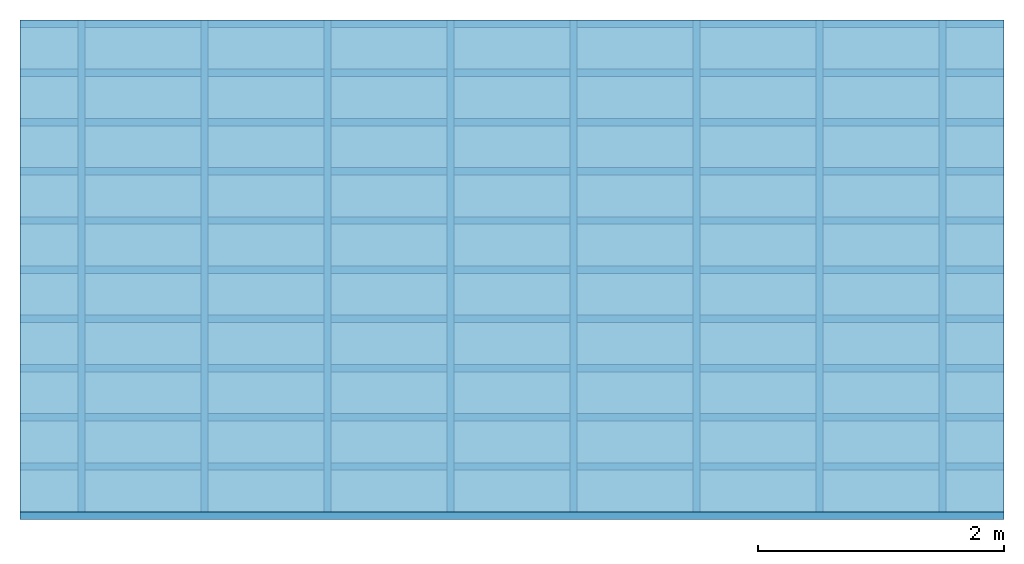
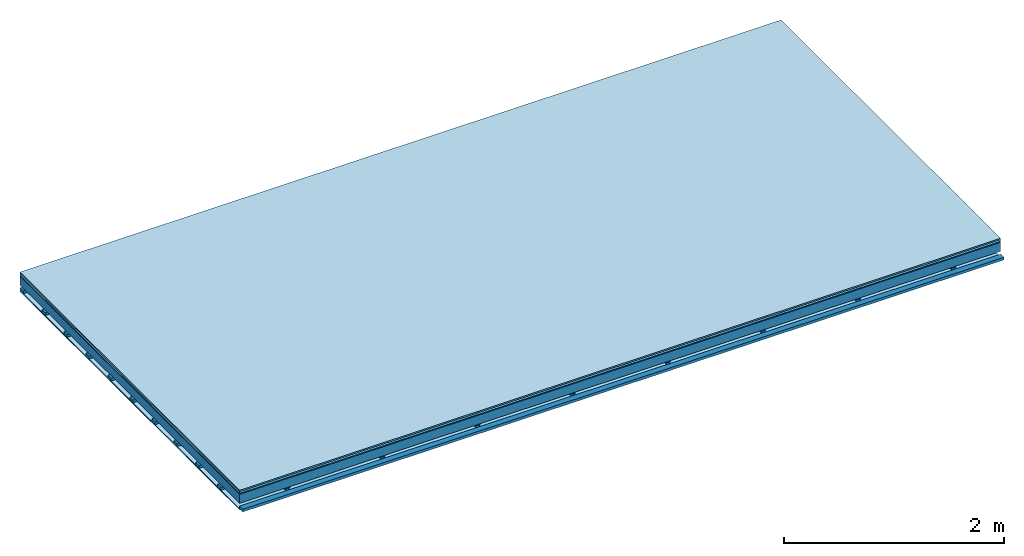
# One storey: 5 plates, 3 members, 1 element without a shape of its own.
"""IFC4 building model written with IfcOpenShell, lengths in metres."""

from ifc_helpers import new_model, si_unit, derived_unit, direction, frame, frame_2d, origin, origin_with_axes, place, context, project, spatial, polyline, rectangle, outline, extrude, material, layer, layer_set, type_object, element, aggregate, save


model = new_model("IFC4")

# Units and contexts
plan_context = context("Plan", 3, precision=1e-05, world=origin(), true_north=direction((0.0, 1.0)))
model_context = context("Model", 3, precision=1e-05, world=origin(), true_north=direction((0.0, 1.0)))
ifc_project = project(units=[si_unit("LENGTHUNIT", "METRE"), derived_unit("SOUNDPRESSUREUNIT", [(si_unit("PRESSUREUNIT", "PASCAL", prefix="MICRO"), 0)]), si_unit("ENERGYUNIT", "JOULE", prefix="MEGA"), si_unit("MASSUNIT", "GRAM", prefix="KILO"), derived_unit("THERMALTRANSMITTANCEUNIT", [(si_unit("POWERUNIT", "WATT"), 1), (si_unit("AREAUNIT", "SQUARE_METRE"), -1), (si_unit("THERMODYNAMICTEMPERATUREUNIT", "KELVIN"), -1)]), derived_unit("AREADENSITYUNIT", [(si_unit("MASSUNIT", "GRAM", prefix="KILO"), 1), (si_unit("AREAUNIT", "SQUARE_METRE"), -1)]), derived_unit("USERDEFINED", [(si_unit("ENERGYUNIT", "JOULE", prefix="MEGA"), 1), (si_unit("AREAUNIT", "SQUARE_METRE"), -1)])], contexts=[plan_context, model_context])

# Site, building, storey
site = spatial("IfcSite", under=ifc_project)
building_placement = place(None, origin())
building = spatial("IfcBuilding", under=site, at=building_placement)
storey_placement = place(building_placement, origin())
storey = spatial("IfcBuildingStorey", under=building, at=storey_placement)

# Slab, members, plates
ifc_material_1 = material(Category="11.013")
ifc_layer_1 = layer(ifc_material_1, 0.015, Name="Flooring")
ifc_material_2 = material(Category="03.007")
ifc_layer_2 = layer(ifc_material_2, 0.02, Name="On-material")
ifc_material_3 = material(Name="Wood fiber generic product", Category="10.009")
ifc_layer_3 = layer(ifc_material_3, 0.01, Name="Impact sound insulation")
ifc_material_4 = material(Name="no composite action")
ifc_layer_4 = layer(ifc_material_4, 0.0, Name="Bond")
ifc_layer_5 = layer(None, 0.1, Name="Supporting structure")
ifc_layer_6 = layer(ifc_material_4, 0.0, Name="Bond")
ifc_layer_7 = layer(None, 0.03, Name="Coupling")
ifc_layer_8 = layer(None, 0.03, Name="Battens / profiles")
ifc_material_5 = material(Name="Plasterboard type A", Category="03.008")
ifc_layer_9 = layer(ifc_material_5, 0.0125, Name="Ceiling covering 1st layer")
ifc_material_6 = material(Category="04.001")
ifc_layer_10 = layer(ifc_material_6, 0.003, Name="Surface / treatment")
ifc_layer_set = layer_set([ifc_layer_1, ifc_layer_2, ifc_layer_3, ifc_layer_4, ifc_layer_5, ifc_layer_6, ifc_layer_7, ifc_layer_8, ifc_layer_9, ifc_layer_10])
slab_type = type_object("IfcSlabType", Name="A2095", PredefinedType="NOTDEFINED", material=ifc_layer_set)
slab_placement = place(None, frame((0.0, 0.0, 0.0), z_axis=(0.0, 0.0, -1.0), x_axis=(1.0, 0.0, 0.0)))
slab = element("IfcSlab", 1, at=slab_placement, inside=storey, type_object=slab_type, material=ifc_layer_set, Name="Slab #1")
ifc_material_7 = material(Name="Solid timber panel")
member_1_placement = place(slab_placement, origin())
member_1 = element("IfcMember", 2, at=member_1_placement, material=ifc_material_7, Name="Supporting structure", context=plan_context, shape_type="SweptSolid", body=[
    extrude(rectangle(XDim=1.0, YDim=0.1, at=frame_2d((0.5, 0.05), x_axis=(1.0, 0.0))), frame((0.0, 4.0, 0.045), z_axis=(0.0, -1.0, 0.0), x_axis=(1.0, 0.0, 0.0)), (0.0, 0.0, 1.0), 4.0),
    extrude(rectangle(XDim=1.0, YDim=0.1, at=frame_2d((0.5, 0.05), x_axis=(1.0, 0.0))), frame((1.0, 4.0, 0.045), z_axis=(0.0, -1.0, 0.0), x_axis=(1.0, 0.0, 0.0)), (0.0, 0.0, 1.0), 4.0),
    extrude(rectangle(XDim=1.0, YDim=0.1, at=frame_2d((0.5, 0.05), x_axis=(1.0, 0.0))), frame((2.0, 4.0, 0.045), z_axis=(0.0, -1.0, 0.0), x_axis=(1.0, 0.0, 0.0)), (0.0, 0.0, 1.0), 4.0),
    extrude(rectangle(XDim=1.0, YDim=0.1, at=frame_2d((0.5, 0.05), x_axis=(1.0, 0.0))), frame((3.0, 4.0, 0.045), z_axis=(0.0, -1.0, 0.0), x_axis=(1.0, 0.0, 0.0)), (0.0, 0.0, 1.0), 4.0),
    extrude(rectangle(XDim=1.0, YDim=0.1, at=frame_2d((0.5, 0.05), x_axis=(1.0, 0.0))), frame((4.0, 4.0, 0.045), z_axis=(0.0, -1.0, 0.0), x_axis=(1.0, 0.0, 0.0)), (0.0, 0.0, 1.0), 4.0),
    extrude(rectangle(XDim=1.0, YDim=0.1, at=frame_2d((0.5, 0.05), x_axis=(1.0, 0.0))), frame((5.0, 4.0, 0.045), z_axis=(0.0, -1.0, 0.0), x_axis=(1.0, 0.0, 0.0)), (0.0, 0.0, 1.0), 4.0),
    extrude(rectangle(XDim=1.0, YDim=0.1, at=frame_2d((0.5, 0.05), x_axis=(1.0, 0.0))), frame((6.0, 4.0, 0.045), z_axis=(0.0, -1.0, 0.0), x_axis=(1.0, 0.0, 0.0)), (0.0, 0.0, 1.0), 4.0),
    extrude(rectangle(XDim=1.0, YDim=0.1, at=frame_2d((0.5, 0.05), x_axis=(1.0, 0.0))), frame((7.0, 4.0, 0.045), z_axis=(0.0, -1.0, 0.0), x_axis=(1.0, 0.0, 0.0)), (0.0, 0.0, 1.0), 4.0),
])
ifc_material_8 = material()
member_2_placement = place(slab_placement, origin())
member_2 = element("IfcMember", 3, at=member_2_placement, material=ifc_material_8, Name="Coupling", context=plan_context, shape_type="SweptSolid", body=[
    extrude(outline(polyline([(0.0, 0.0), (0.06, 0.0), (0.04, 0.02), (0.02, 0.02), (0.0, 0.0)])), frame((0.47, 4.0, 0.155), z_axis=(0.0, -1.0, 0.0), x_axis=(1.0, 0.0, 0.0)), (0.0, 0.0, 1.0), 4.0),
    extrude(outline(polyline([(0.0, 0.0), (0.06, 0.0), (0.04, 0.02), (0.02, 0.02), (0.0, 0.0)])), frame((1.47, 4.0, 0.155), z_axis=(0.0, -1.0, 0.0), x_axis=(1.0, 0.0, 0.0)), (0.0, 0.0, 1.0), 4.0),
    extrude(outline(polyline([(0.0, 0.0), (0.06, 0.0), (0.04, 0.02), (0.02, 0.02), (0.0, 0.0)])), frame((2.47, 4.0, 0.155), z_axis=(0.0, -1.0, 0.0), x_axis=(1.0, 0.0, 0.0)), (0.0, 0.0, 1.0), 4.0),
    extrude(outline(polyline([(0.0, 0.0), (0.06, 0.0), (0.04, 0.02), (0.02, 0.02), (0.0, 0.0)])), frame((3.47, 4.0, 0.155), z_axis=(0.0, -1.0, 0.0), x_axis=(1.0, 0.0, 0.0)), (0.0, 0.0, 1.0), 4.0),
    extrude(outline(polyline([(0.0, 0.0), (0.06, 0.0), (0.04, 0.02), (0.02, 0.02), (0.0, 0.0)])), frame((4.47, 4.0, 0.155), z_axis=(0.0, -1.0, 0.0), x_axis=(1.0, 0.0, 0.0)), (0.0, 0.0, 1.0), 4.0),
    extrude(outline(polyline([(0.0, 0.0), (0.06, 0.0), (0.04, 0.02), (0.02, 0.02), (0.0, 0.0)])), frame((5.47, 4.0, 0.155), z_axis=(0.0, -1.0, 0.0), x_axis=(1.0, 0.0, 0.0)), (0.0, 0.0, 1.0), 4.0),
    extrude(outline(polyline([(0.0, 0.0), (0.06, 0.0), (0.04, 0.02), (0.02, 0.02), (0.0, 0.0)])), frame((6.47, 4.0, 0.155), z_axis=(0.0, -1.0, 0.0), x_axis=(1.0, 0.0, 0.0)), (0.0, 0.0, 1.0), 4.0),
    extrude(outline(polyline([(0.0, 0.0), (0.06, 0.0), (0.04, 0.02), (0.02, 0.02), (0.0, 0.0)])), frame((7.47, 4.0, 0.155), z_axis=(0.0, -1.0, 0.0), x_axis=(1.0, 0.0, 0.0)), (0.0, 0.0, 1.0), 4.0),
])
member_3_placement = place(slab_placement, origin())
member_3 = element("IfcMember", 4, at=member_3_placement, material=ifc_material_8, Name="Battens / profiles", context=plan_context, shape_type="SweptSolid", body=[
    extrude(rectangle(XDim=0.06, YDim=0.03, at=frame_2d((0.03, 0.015), x_axis=(1.0, 0.0))), frame((0.0, 0.0, 0.175), z_axis=(1.0, 0.0, 0.0), x_axis=(0.0, 1.0, 0.0)), (0.0, 0.0, 1.0), 8.0),
    extrude(rectangle(XDim=0.06, YDim=0.03, at=frame_2d((0.03, 0.015), x_axis=(1.0, 0.0))), frame((0.0, 0.4, 0.175), z_axis=(1.0, 0.0, 0.0), x_axis=(0.0, 1.0, 0.0)), (0.0, 0.0, 1.0), 8.0),
    extrude(rectangle(XDim=0.06, YDim=0.03, at=frame_2d((0.03, 0.015), x_axis=(1.0, 0.0))), frame((0.0, 0.8, 0.175), z_axis=(1.0, 0.0, 0.0), x_axis=(0.0, 1.0, 0.0)), (0.0, 0.0, 1.0), 8.0),
    extrude(rectangle(XDim=0.06, YDim=0.03, at=frame_2d((0.03, 0.015), x_axis=(1.0, 0.0))), frame((0.0, 1.2, 0.175), z_axis=(1.0, 0.0, 0.0), x_axis=(0.0, 1.0, 0.0)), (0.0, 0.0, 1.0), 8.0),
    extrude(rectangle(XDim=0.06, YDim=0.03, at=frame_2d((0.03, 0.015), x_axis=(1.0, 0.0))), frame((0.0, 1.6, 0.175), z_axis=(1.0, 0.0, 0.0), x_axis=(0.0, 1.0, 0.0)), (0.0, 0.0, 1.0), 8.0),
    extrude(rectangle(XDim=0.06, YDim=0.03, at=frame_2d((0.03, 0.015), x_axis=(1.0, 0.0))), frame((0.0, 2.0, 0.175), z_axis=(1.0, 0.0, 0.0), x_axis=(0.0, 1.0, 0.0)), (0.0, 0.0, 1.0), 8.0),
    extrude(rectangle(XDim=0.06, YDim=0.03, at=frame_2d((0.03, 0.015), x_axis=(1.0, 0.0))), frame((0.0, 2.4, 0.175), z_axis=(1.0, 0.0, 0.0), x_axis=(0.0, 1.0, 0.0)), (0.0, 0.0, 1.0), 8.0),
    extrude(rectangle(XDim=0.06, YDim=0.03, at=frame_2d((0.03, 0.015), x_axis=(1.0, 0.0))), frame((0.0, 2.8, 0.175), z_axis=(1.0, 0.0, 0.0), x_axis=(0.0, 1.0, 0.0)), (0.0, 0.0, 1.0), 8.0),
    extrude(rectangle(XDim=0.06, YDim=0.03, at=frame_2d((0.03, 0.015), x_axis=(1.0, 0.0))), frame((0.0, 3.2, 0.175), z_axis=(1.0, 0.0, 0.0), x_axis=(0.0, 1.0, 0.0)), (0.0, 0.0, 1.0), 8.0),
    extrude(rectangle(XDim=0.06, YDim=0.03, at=frame_2d((0.03, 0.015), x_axis=(1.0, 0.0))), frame((0.0, 3.6, 0.175), z_axis=(1.0, 0.0, 0.0), x_axis=(0.0, 1.0, 0.0)), (0.0, 0.0, 1.0), 8.0),
    extrude(rectangle(XDim=0.06, YDim=0.03, at=frame_2d((0.03, 0.015), x_axis=(1.0, 0.0))), frame((0.0, 4.0, 0.175), z_axis=(1.0, 0.0, 0.0), x_axis=(0.0, 1.0, 0.0)), (0.0, 0.0, 1.0), 8.0),
])
plate_1_placement = place(slab_placement, origin())
plate_1 = element("IfcPlate", 5, at=plate_1_placement, material=ifc_material_1, Name="Flooring", context=plan_context, shape_type="SweptSolid", body=[
    extrude(rectangle(XDim=8.0, YDim=4.0, at=frame_2d((4.0, 2.0), x_axis=(1.0, 0.0))), origin_with_axes(), (0.0, 0.0, 1.0), 0.015),
])
plate_2_placement = place(slab_placement, origin())
plate_2 = element("IfcPlate", 6, at=plate_2_placement, material=ifc_material_2, Name="On-material", context=plan_context, shape_type="SweptSolid", body=[
    extrude(rectangle(XDim=8.0, YDim=4.0, at=frame_2d((4.0, 2.0), x_axis=(1.0, 0.0))), frame((0.0, 0.0, 0.015), z_axis=(0.0, 0.0, 1.0), x_axis=(1.0, 0.0, 0.0)), (0.0, 0.0, 1.0), 0.02),
])
plate_3_placement = place(slab_placement, origin())
plate_3 = element("IfcPlate", 7, at=plate_3_placement, material=ifc_material_3, Name="Impact sound insulation", context=plan_context, shape_type="SweptSolid", body=[
    extrude(rectangle(XDim=8.0, YDim=4.0, at=frame_2d((4.0, 2.0), x_axis=(1.0, 0.0))), frame((0.0, 0.0, 0.035), z_axis=(0.0, 0.0, 1.0), x_axis=(1.0, 0.0, 0.0)), (0.0, 0.0, 1.0), 0.01),
])
plate_4_placement = place(slab_placement, origin())
plate_4 = element("IfcPlate", 8, at=plate_4_placement, material=ifc_material_5, Name="Ceiling covering 1st layer", context=plan_context, shape_type="SweptSolid", body=[
    extrude(rectangle(XDim=8.0, YDim=4.0, at=frame_2d((4.0, 2.0), x_axis=(1.0, 0.0))), frame((0.0, 0.0, 0.205), z_axis=(0.0, 0.0, 1.0), x_axis=(1.0, 0.0, 0.0)), (0.0, 0.0, 1.0), 0.0125),
])
plate_5_placement = place(slab_placement, origin())
plate_5 = element("IfcPlate", 9, at=plate_5_placement, material=ifc_material_6, Name="Surface / treatment", context=plan_context, shape_type="SweptSolid", body=[
    extrude(rectangle(XDim=8.0, YDim=4.0, at=frame_2d((4.0, 2.0), x_axis=(1.0, 0.0))), frame((0.0, 0.0, 0.2175), z_axis=(0.0, 0.0, 1.0), x_axis=(1.0, 0.0, 0.0)), (0.0, 0.0, 1.0), 0.003),
])
aggregate(slab, [plate_1, plate_2, plate_3, member_1, member_2, member_3, plate_4, plate_5])

save(model, "model.ifc")
